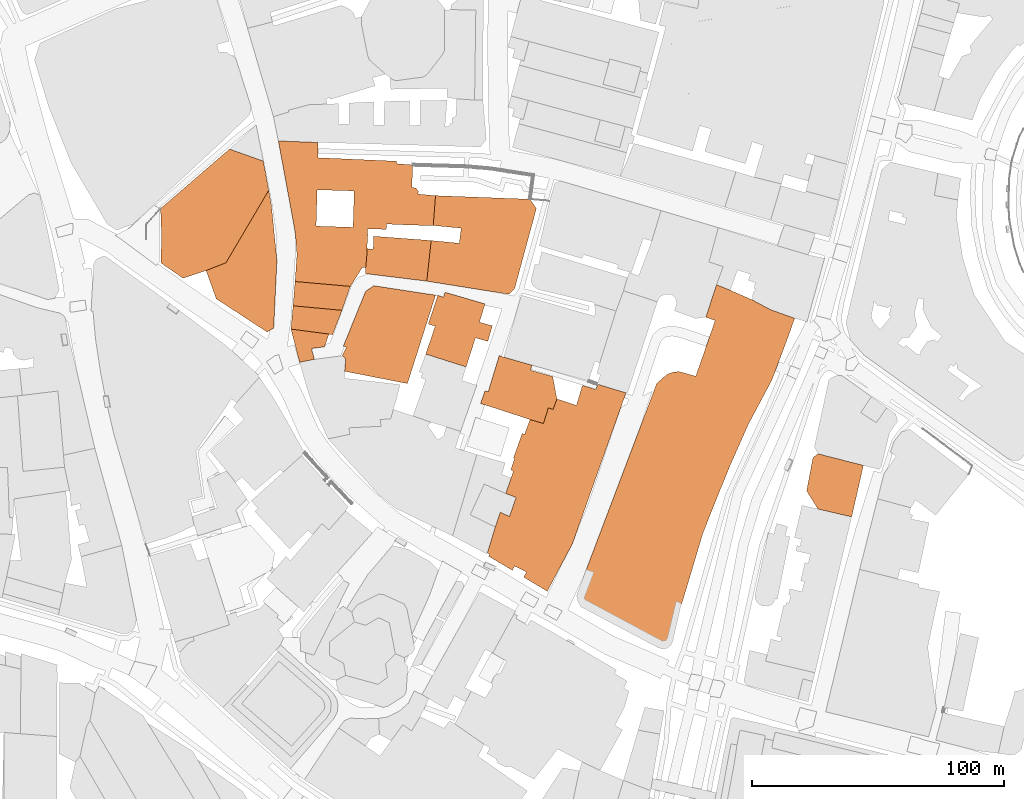
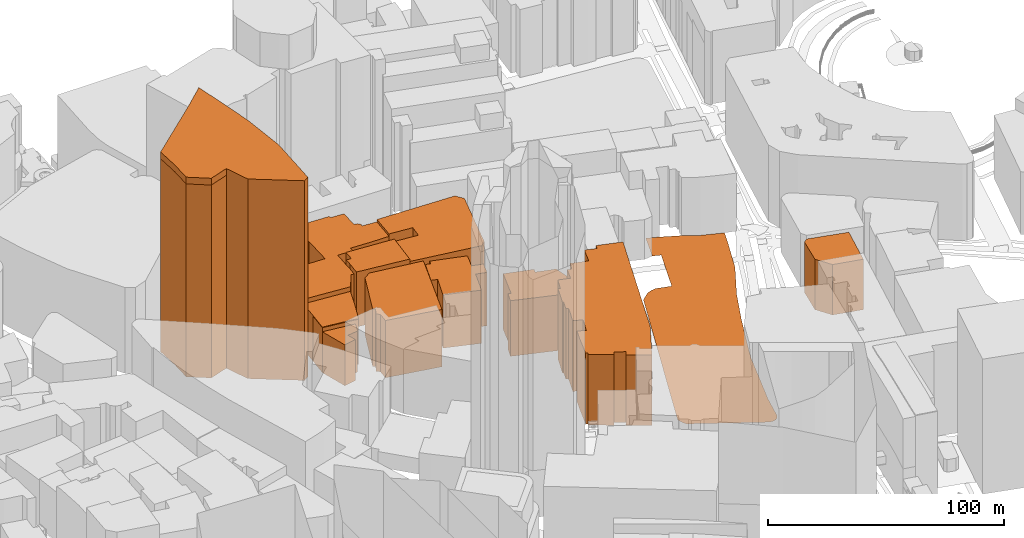
# One storey, part 193 of 200: 14 proxies.
"""IFC4 building model written with IfcOpenShell, lengths in metres."""

from ifc_helpers import new_model, si_unit, origin_with_axes, place, context, subcontext, project, spatial, triangles, material, element, save


model = new_model("IFC4")

# Units and contexts
model_context = context("Model", 3, precision=1e-05, world=origin_with_axes())
body_context = subcontext(model_context, "Body", "Model", "MODEL_VIEW")
ifc_project = project(units=[si_unit("VOLUMEUNIT", "CUBIC_METRE"), si_unit("LENGTHUNIT", "METRE"), si_unit("AREAUNIT", "SQUARE_METRE")], contexts=[model_context])

# Site, building, storey
site_placement = place(None, origin_with_axes())
site = spatial("IfcSite", under=ifc_project, at=site_placement)
building_placement = place(site_placement, origin_with_axes())
building = spatial("IfcBuilding", under=site, at=building_placement, Name="Building")
storey_placement = place(building_placement, origin_with_axes())
storey = spatial("IfcBuildingStorey", under=building, at=storey_placement, Name="Ground")

# Proxies
ifc_material_1 = material()
proxy_1_placement = place(storey_placement, origin_with_axes())
element("IfcBuildingElementProxy", 1, at=proxy_1_placement, inside=storey, material=ifc_material_1, Name="cw_buildings_UK 49", context=body_context, shape_type="Tessellation", body=[
    triangles([(573.4480823661622, -129.90144368040757, 26.014001846313477), (573.0067262512358, -144.32679761538287, 26.014001846313477), (598.6982542588236, -131.13260069638554, 26.014001846313477), (559.1853315662346, -116.73047578070275, 26.014001846313477), (578.7675752678352, -144.90753259443306, 26.014001846313477), (543.3894559962635, -110.06368076658927, 26.014001846313477), (576.7001735573266, -160.19236024323155, 26.014001846313477), (558.7904334898932, -129.4368632945572, 26.014001846313477), (550.7531215891524, -155.10516703122107, 26.014001846313477), (578.0010081344449, -160.30851483643139, 26.014001846313477), (586.2938439957718, -143.0027340189721, 26.014001846313477), (596.3521019426204, -128.50769302611923, 26.014001846313477), (549.5684321084968, -143.58346899802228, 26.014001846313477), (550.1491623391784, -147.2304535171594, 26.014001846313477), (550.0097882234232, -165.81383989244446, 26.014001846313477), (578.4888222879564, -152.80546563105003, 26.014001846313477), (581.3227911318553, -144.9307616137256, 26.014001846313477), (604.8075409389951, -143.6066980173148, 26.014001846313477), (598.9770048645181, -130.0175982736074, 26.014001846313477), (590.289273301034, -119.0998547420141, 26.014001846313477), (559.115644508357, -114.03588105255888, 26.014001846313477), (547.4313433401106, -131.99207441020872, 26.014001846313477), (558.5349142776755, -137.66001209800663, 26.014001846313477), (571.9381818670428, -167.74186748719796, 26.014001846313477), (578.4191352300788, -156.22016945399918, 26.014001846313477), (578.8372623257128, -147.57888880654716, 26.014001846313477), (586.1312408607242, -145.1862808259433, 26.014001846313477), (595.748140318462, -143.44408538552992, 26.014001846313477), (605.6902519817559, -131.7597842172835, 26.014001846313477), (597.7923130096781, -128.71675419975188, 26.014001846313477), (596.6308525483149, -119.58767364389423, 26.014001846313477), (590.1731258303871, -118.10099741569857, 26.014001846313477), (559.115644508357, -110.69087378422451, 26.014001846313477), (544.0166442655301, -113.52484262812348, 26.014001846313477), (558.3490821233353, -143.83898821024, 26.014001846313477), (576.7001735573266, -160.19236024323155, 0.0), (578.0010081344449, -160.30851483643139, 0.0), (571.9381818670428, -167.74186748719796, 0.0), (550.0097882234232, -165.81383989244446, 0.0), (550.7531215891524, -155.10516703122107, 0.0), (550.1491623391784, -147.2304535171594, 0.0), (549.5684321084968, -143.58346899802228, 0.0), (547.4313433401106, -131.99207441020872, 0.0), (544.0166442655301, -113.52484262812348, 0.0), (543.3894559962635, -110.06368076658927, 0.0), (559.115644508357, -110.69087378422451, 0.0), (559.115644508357, -114.03588105255888, 0.0), (559.1853315662346, -116.73047578070275, 0.0), (590.1731258303871, -118.10099741569857, 0.0), (590.289273301034, -119.0998547420141, 0.0), (596.6308525483149, -119.58767364389423, 0.0), (596.3521019426204, -128.50769302611923, 0.0), (597.7923130096781, -128.71675419975188, 0.0), (598.9770048645181, -130.0175982736074, 0.0), (598.6982542588236, -131.13260069638554, 0.0), (605.6902519817559, -131.7597842172835, 0.0), (604.8075409389951, -143.6066980173148, 0.0), (595.748140318462, -143.44408538552992, 0.0), (586.2938439957718, -143.0027340189721, 0.0), (586.1312408607242, -145.1862808259433, 0.0), (581.3227911318553, -144.9307616137256, 0.0), (578.7675752678352, -144.90753259443306, 0.0), (578.8372623257128, -147.57888880654716, 0.0), (578.4888222879564, -152.80546563105003, 0.0), (578.4191352300788, -156.22016945399918, 0.0), (558.5349142776755, -137.66001209800663, 0.0), (558.7904334898932, -129.4368632945572, 0.0), (558.3490821233353, -143.83898821024, 0.0), (573.0067262512358, -144.32679761538287, 0.0), (573.4480823661622, -129.90144368040757, 0.0)], [[1, 2, 3], [3, 4, 1], [2, 5, 3], [4, 6, 1], [2, 7, 5], [6, 8, 1], [2, 9, 7], [7, 10, 5], [5, 11, 3], [3, 12, 4], [6, 13, 8], [2, 14, 9], [9, 15, 7], [10, 16, 5], [5, 17, 11], [11, 18, 3], [3, 19, 12], [12, 20, 4], [4, 21, 6], [6, 22, 13], [13, 23, 8], [2, 13, 14], [15, 24, 7], [10, 25, 16], [16, 26, 5], [17, 27, 11], [11, 28, 18], [18, 29, 3], [19, 30, 12], [12, 31, 20], [20, 32, 4], [21, 33, 6], [6, 34, 22], [13, 35, 23], [2, 35, 13], [36, 37, 10], [36, 10, 7], [38, 36, 7], [38, 7, 24], [39, 38, 24], [39, 24, 15], [40, 39, 15], [40, 15, 9], [41, 40, 9], [41, 9, 14], [42, 41, 14], [42, 14, 13], [43, 42, 13], [43, 13, 22], [44, 43, 22], [44, 22, 34], [45, 44, 34], [45, 34, 6], [46, 45, 6], [46, 6, 33], [47, 46, 33], [47, 33, 21], [48, 47, 21], [48, 21, 4], [49, 48, 4], [49, 4, 32], [50, 49, 32], [50, 32, 20], [51, 50, 20], [51, 20, 31], [52, 51, 31], [52, 31, 12], [53, 52, 12], [53, 12, 30], [54, 53, 30], [54, 30, 19], [55, 54, 19], [55, 19, 3], [56, 55, 3], [56, 3, 29], [57, 56, 29], [57, 29, 18], [58, 57, 18], [58, 18, 28], [59, 58, 28], [59, 28, 11], [60, 59, 11], [60, 11, 27], [61, 60, 27], [61, 27, 17], [62, 61, 17], [62, 17, 5], [63, 62, 5], [63, 5, 26], [64, 63, 26], [64, 26, 16], [65, 64, 16], [65, 16, 25], [37, 65, 25], [37, 25, 10], [66, 67, 8], [66, 8, 23], [68, 66, 23], [68, 23, 35], [69, 68, 35], [69, 35, 2], [70, 69, 2], [70, 2, 1], [67, 70, 1], [67, 1, 8], [42, 68, 69], [66, 68, 42], [43, 44, 45], [45, 46, 47], [48, 49, 50], [50, 51, 52], [52, 53, 54], [55, 56, 57], [57, 58, 59], [59, 60, 61], [62, 63, 64], [64, 65, 37], [36, 38, 39], [41, 42, 69], [67, 66, 42], [42, 43, 45], [45, 47, 48], [48, 50, 52], [52, 54, 55], [55, 57, 59], [59, 61, 62], [62, 64, 37], [36, 39, 40], [40, 41, 69], [67, 42, 45], [48, 52, 55], [55, 59, 62], [62, 37, 36], [36, 40, 69], [70, 67, 45], [62, 36, 69], [70, 45, 48], [55, 62, 69], [70, 48, 55], [55, 69, 70]], closed=False),
])
proxy_2_placement = place(storey_placement, origin_with_axes())
element("IfcBuildingElementProxy", 2, at=proxy_2_placement, inside=storey, material=ifc_material_1, Name="cw_buildings_UK 55", context=body_context, shape_type="Tessellation", body=[
    triangles([(605.5973347174936, -183.53774305716908, 27.597003936767578), (621.5325870741772, -188.13713636077395, 27.597003936767578), (623.1354040214331, -181.95815075180334, 27.597003936767578), (608.84942709575, -172.03927404326282, 27.597003936767578), (601.7877423149403, -194.59486070451752, 27.597003936767578), (626.4107253447888, -189.55410653761757, 27.597003936767578), (625.2957223284646, -174.6874012360844, 27.597003936767578), (602.7865984541636, -182.65503082731615, 27.597003936767578), (617.8159101552478, -199.682053916528, 27.597003936767578), (628.2458344881879, -183.35191090282893, 27.597003936767578), (609.4301585135238, -170.0647884099243, 27.597003936767578), (606.6194210631016, -171.295935929165, 27.597003936767578), (609.4301585135238, -170.0647884099243, 0.0), (608.84942709575, -172.03927404326282, 0.0), (625.2957223284646, -174.6874012360844, 0.0), (623.1354040214331, -181.95815075180334, 0.0), (628.2458344881879, -183.35191090282893, 0.0), (626.4107253447888, -189.55410653761757, 0.0), (621.5325870741772, -188.13713636077395, 0.0), (617.8159101552478, -199.682053916528, 0.0), (601.7877423149403, -194.59486070451752, 0.0), (605.5973347174936, -183.53774305716908, 0.0), (602.7865984541636, -182.65503082731615, 0.0), (606.6194210631016, -171.295935929165, 0.0)], [[1, 2, 3], [3, 4, 1], [1, 5, 2], [2, 6, 3], [3, 7, 4], [4, 8, 1], [5, 9, 2], [6, 10, 3], [7, 11, 4], [4, 12, 8], [13, 14, 4], [13, 4, 11], [15, 13, 11], [15, 11, 7], [16, 15, 7], [16, 7, 3], [17, 16, 3], [17, 3, 10], [18, 17, 10], [18, 10, 6], [19, 18, 6], [19, 6, 2], [20, 19, 2], [20, 2, 9], [21, 20, 9], [21, 9, 5], [22, 21, 5], [22, 5, 1], [23, 22, 1], [23, 1, 8], [24, 23, 8], [24, 8, 12], [14, 24, 12], [14, 12, 4], [23, 24, 14], [14, 13, 15], [16, 17, 18], [19, 20, 21], [22, 23, 14], [14, 15, 16], [16, 18, 19], [19, 21, 22], [22, 14, 16], [16, 19, 22]], closed=False),
])
proxy_3_placement = place(storey_placement, origin_with_axes())
element("IfcBuildingElementProxy", 3, at=proxy_3_placement, inside=storey, material=ifc_material_1, Name="cw_buildings_UK 59", context=body_context, shape_type="Tessellation", body=[
    triangles([(637.6304431594544, -251.43678373712103, 36.62324142456055), (635.0055402375568, -258.96304296832045, 36.62324142456055), (650.0116232161215, -288.6500145262762, 36.62324142456055), (640.9986818212657, -226.39567301809242, 36.62324142456055), (641.7420175611792, -281.0075912051397, 36.62324142456055), (661.5797792879054, -214.89719450744892, 36.62324142456055), (640.0462837206273, -226.07046674799716, 36.62324142456055), (637.0961709673579, -278.6149832245358, 36.62324142456055), (669.3383429571358, -208.67176035663056, 36.62324142456055), (648.4784936977095, -222.09826646202757, 36.62324142456055), (636.5386697559688, -240.96040106882285, 36.62324142456055), (627.1772901039949, -273.94591235979067, 36.62324142456055), (669.9190731878174, -206.51144256895185, 36.62324142456055), (652.3345465130321, -216.52324485139968, 36.62324142456055), (637.0729419480654, -235.9196469019229, 36.62324142456055), (635.7024179388852, -243.67821531952197, 36.62324142456055), (629.3608375045121, -263.1210754086302, 36.62324142456055), (626.712705563322, -274.71246999644376, 36.62324142456055), (681.2317100473834, -209.97260443048606, 36.62324142456055), (669.6170959370146, -207.55676743058967, 36.62324142456055), (663.9723920168778, -206.92958390969167, 36.62324142456055), (653.8212179928591, -212.38844143038244, 36.62324142456055), (650.4297503117555, -215.8960613305017, 36.62324142456055), (643.1590007960365, -220.54190317595433, 36.62324142456055), (636.585127794554, -235.78027278616779, 36.62324142456055), (635.5165834103608, -240.519049702265, 36.62324142456055), (633.5188699448219, -249.8571914317553, 36.62324142456055), (631.3353225443046, -257.29055357925915, 36.62324142456055), (626.2713500419416, -273.38839690329576, 36.62324142456055), (636.1670018860121, -280.3339496456567, 36.62324142456055), (640.6037849320164, -283.0053058577708, 36.62324142456055), (660.0234207502008, -269.74142188089587, 36.62324142456055), (640.6037849320164, -283.0053058577708, 0.0), (650.0116232161215, -288.6500145262762, 0.0), (641.7420175611792, -281.0075912051397, 0.0), (637.0961709673579, -278.6149832245358, 0.0), (636.1670018860121, -280.3339496456567, 0.0), (626.712705563322, -274.71246999644376, 0.0), (627.1772901039949, -273.94591235979067, 0.0), (626.2713500419416, -273.38839690329576, 0.0), (629.3608375045121, -263.1210754086302, 0.0), (631.3353225443046, -257.29055357925915, 0.0), (635.0055402375568, -258.96304296832045, 0.0), (637.6304431594544, -251.43678373712103, 0.0), (633.5188699448219, -249.8571914317553, 0.0), (635.7024179388852, -243.67821531952197, 0.0), (636.5386697559688, -240.96040106882285, 0.0), (635.5165834103608, -240.519049702265, 0.0), (637.0729419480654, -235.9196469019229, 0.0), (636.585127794554, -235.78027278616779, 0.0), (640.0462837206273, -226.07046674799716, 0.0), (640.9986818212657, -226.39567301809242, 0.0), (643.1590007960365, -220.54190317595433, 0.0), (648.4784936977095, -222.09826646202757, 0.0), (650.4297503117555, -215.8960613305017, 0.0), (652.3345465130321, -216.52324485139968, 0.0), (653.8212179928591, -212.38844143038244, 0.0), (661.5797792879054, -214.89719450744892, 0.0), (663.9723920168778, -206.92958390969167, 0.0), (669.3383429571358, -208.67176035663056, 0.0), (669.6170959370146, -207.55676743058967, 0.0), (669.9190731878174, -206.51144256895185, 0.0), (681.2317100473834, -209.97260443048606, 0.0), (660.0234207502008, -269.74142188089587, 0.0)], [[1, 2, 3], [3, 4, 1], [2, 5, 3], [3, 6, 4], [4, 7, 1], [2, 8, 5], [3, 9, 6], [6, 10, 4], [7, 11, 1], [2, 12, 8], [3, 13, 9], [6, 14, 10], [7, 15, 11], [11, 16, 1], [2, 17, 12], [12, 18, 8], [3, 19, 13], [13, 20, 9], [9, 21, 6], [6, 22, 14], [14, 23, 10], [10, 24, 4], [7, 25, 15], [15, 26, 11], [16, 27, 1], [2, 28, 17], [17, 29, 12], [18, 30, 8], [5, 31, 3], [3, 32, 19], [33, 34, 3], [33, 3, 31], [35, 33, 31], [35, 31, 5], [36, 35, 5], [36, 5, 8], [37, 36, 8], [37, 8, 30], [38, 37, 30], [38, 30, 18], [39, 38, 18], [39, 18, 12], [40, 39, 12], [40, 12, 29], [41, 40, 29], [41, 29, 17], [42, 41, 17], [42, 17, 28], [43, 42, 28], [43, 28, 2], [44, 43, 2], [44, 2, 1], [45, 44, 1], [45, 1, 27], [46, 45, 27], [46, 27, 16], [47, 46, 16], [47, 16, 11], [48, 47, 11], [48, 11, 26], [49, 48, 26], [49, 26, 15], [50, 49, 15], [50, 15, 25], [51, 50, 25], [51, 25, 7], [52, 51, 7], [52, 7, 4], [53, 52, 4], [53, 4, 24], [54, 53, 24], [54, 24, 10], [55, 54, 10], [55, 10, 23], [56, 55, 23], [56, 23, 14], [57, 56, 14], [57, 14, 22], [58, 57, 22], [58, 22, 6], [59, 58, 6], [59, 6, 21], [60, 59, 21], [60, 21, 9], [61, 60, 9], [61, 9, 20], [62, 61, 20], [62, 20, 13], [63, 62, 13], [63, 13, 19], [64, 63, 19], [64, 19, 32], [34, 64, 32], [34, 32, 3], [63, 64, 34], [34, 33, 35], [36, 37, 38], [39, 40, 41], [41, 42, 43], [44, 45, 46], [47, 48, 49], [49, 50, 51], [52, 53, 54], [54, 55, 56], [56, 57, 58], [58, 59, 60], [60, 61, 62], [62, 63, 34], [36, 38, 39], [39, 41, 43], [44, 46, 47], [47, 49, 51], [54, 56, 58], [60, 62, 34], [36, 39, 43], [44, 47, 51], [52, 54, 58], [58, 60, 34], [35, 36, 43], [44, 51, 52], [52, 58, 34], [34, 35, 43], [44, 52, 34], [34, 43, 44]], closed=False),
])
proxy_4_placement = place(storey_placement, origin_with_axes())
element("IfcBuildingElementProxy", 4, at=proxy_4_placement, inside=storey, material=ifc_material_1, Name="cw_buildings_UK 61", context=body_context, shape_type="Tessellation", body=[
    triangles([(626.5733299637017, -209.57771110251323, 28.83700180053711), (650.4297503117555, -215.8960613305017, 28.83700180053711), (643.344835324561, -200.98289799038352, 28.83700180053711), (643.7165020074256, -199.77496999369808, 28.83700180053711), (643.1590007960365, -220.54190317595433, 28.83700180053711), (653.8212179928591, -212.38844143038244, 28.83700180053711), (632.7290761663234, -195.77954068843593, 28.83700180053711), (625.3421809605958, -209.13635973595538, 28.83700180053711), (648.4784936977095, -222.09826646202757, 28.83700180053711), (652.3345465130321, -216.52324485139968, 28.83700180053711), (652.1719410038002, -203.49165106744996, 28.83700180053711), (643.9487945745351, -198.96195431845993, 28.83700180053711), (630.9404256550554, -195.2220442254155, 28.83700180053711), (623.5535301525547, -214.15386589008833, 28.83700180053711), (626.5733299637017, -209.57771110251323, 0.0), (625.3421809605958, -209.13635973595538, 0.0), (630.9404256550554, -195.2220442254155, 0.0), (632.7290761663234, -195.77954068843593, 0.0), (643.9487945745351, -198.96195431845993, 0.0), (643.7165020074256, -199.77496999369808, 0.0), (643.344835324561, -200.98289799038352, 0.0), (652.1719410038002, -203.49165106744996, 0.0), (653.8212179928591, -212.38844143038244, 0.0), (652.3345465130321, -216.52324485139968, 0.0), (650.4297503117555, -215.8960613305017, 0.0), (648.4784936977095, -222.09826646202757, 0.0), (643.1590007960365, -220.54190317595433, 0.0), (623.5535301525547, -214.15386589008833, 0.0)], [[1, 2, 3], [3, 4, 1], [1, 5, 2], [2, 6, 3], [4, 7, 1], [1, 8, 5], [5, 9, 2], [2, 10, 6], [6, 11, 3], [4, 12, 7], [7, 13, 1], [8, 14, 5], [15, 16, 8], [15, 8, 1], [17, 15, 1], [17, 1, 13], [18, 17, 13], [18, 13, 7], [19, 18, 7], [19, 7, 12], [20, 19, 12], [20, 12, 4], [21, 20, 4], [21, 4, 3], [22, 21, 3], [22, 3, 11], [23, 22, 11], [23, 11, 6], [24, 23, 6], [24, 6, 10], [25, 24, 10], [25, 10, 2], [26, 25, 2], [26, 2, 9], [27, 26, 9], [27, 9, 5], [28, 27, 5], [28, 5, 14], [16, 28, 14], [16, 14, 8], [27, 28, 16], [15, 17, 18], [18, 19, 20], [21, 22, 23], [23, 24, 25], [25, 26, 27], [27, 16, 15], [15, 18, 20], [21, 23, 25], [25, 27, 15], [15, 20, 21], [21, 25, 15]], closed=False),
])
proxy_5_placement = place(storey_placement, origin_with_axes())
element("IfcBuildingElementProxy", 5, at=proxy_5_placement, inside=storey, material=ifc_material_1, Name="cw_buildings_UK 62", context=body_context, shape_type="Tessellation", body=[
    triangles([(570.0798413301668, -196.476430260686, 29.709003448486328), (603.4602459491074, -178.33439525195877, 29.709003448486328), (577.9545500958598, -169.73958213982903, 29.709003448486328), (570.2889025037995, -191.9002564796364, 29.709003448486328), (569.6617142345328, -201.40102033764884, 29.709003448486328), (605.7134810010483, -171.22624887128745, 29.709003448486328), (569.1506710617288, -191.43567609378604, 29.709003448486328), (568.7093149468024, -195.2220442254155, 29.709003448486328), (594.5634508378063, -206.27915237602667, 29.709003448486328), (604.296497766191, -175.732716600985, 29.709003448486328), (581.2066412870241, -167.486338778243, 29.709003448486328), (604.296497766191, -175.732716600985, 0.0), (605.7134810010483, -171.22624887128745, 0.0), (603.4602459491074, -178.33439525195877, 0.0), (594.5634508378063, -206.27915237602667, 0.0), (569.6617142345328, -201.40102033764884, 0.0), (570.0798413301668, -196.476430260686, 0.0), (568.7093149468024, -195.2220442254155, 0.0), (570.2889025037995, -191.9002564796364, 0.0), (569.1506710617288, -191.43567609378604, 0.0), (577.9545500958598, -169.73958213982903, 0.0), (581.2066412870241, -167.486338778243, 0.0)], [[1, 2, 3], [3, 4, 1], [1, 5, 2], [2, 6, 3], [3, 7, 4], [4, 8, 1], [5, 9, 2], [2, 10, 6], [6, 11, 3], [12, 13, 6], [12, 6, 10], [14, 12, 10], [14, 10, 2], [15, 14, 2], [15, 2, 9], [16, 15, 9], [16, 9, 5], [17, 16, 5], [17, 5, 1], [18, 17, 1], [18, 1, 8], [19, 18, 8], [19, 8, 4], [20, 19, 4], [20, 4, 7], [21, 20, 7], [21, 7, 3], [22, 21, 3], [22, 3, 11], [13, 22, 11], [13, 11, 6], [21, 22, 13], [13, 12, 14], [14, 15, 16], [17, 18, 19], [19, 20, 21], [21, 13, 14], [14, 16, 17], [17, 19, 21], [21, 14, 17]], closed=False),
])
proxy_6_placement = place(storey_placement, origin_with_axes())
element("IfcBuildingElementProxy", 6, at=proxy_6_placement, inside=storey, material=ifc_material_1, Name="cw_buildings_UK 81", context=body_context, shape_type="Tessellation", body=[
    triangles([(755.3794138974463, -235.5479825932426, 26.13800048828125), (757.3074414921998, -256.01293852469615, 26.13800048828125), (773.0336300042934, -248.85834360217703, 26.13800048828125), (775.3565509270197, -238.73039622326658, 26.13800048828125), (752.8474223043501, -248.8351145828845, 26.13800048828125), (770.6874800622745, -259.14889411613507, 26.13800048828125), (757.3538995307849, -234.10778339710646, 26.13800048828125), (773.0336300042934, -248.85834360217703, 0.0), (775.3565509270197, -238.73039622326658, 0.0), (770.6874800622745, -259.14889411613507, 0.0), (757.3074414921998, -256.01293852469615, 0.0), (752.8474223043501, -248.8351145828845, 0.0), (755.3794138974463, -235.5479825932426, 0.0), (757.3538995307849, -234.10778339710646, 0.0)], [[1, 2, 3], [3, 4, 1], [1, 5, 2], [2, 6, 3], [4, 7, 1], [8, 9, 4], [8, 4, 3], [10, 8, 3], [10, 3, 6], [11, 10, 6], [11, 6, 2], [12, 11, 2], [12, 2, 5], [13, 12, 5], [13, 5, 1], [14, 13, 1], [14, 1, 7], [9, 14, 7], [9, 7, 4], [13, 14, 9], [8, 10, 11], [11, 12, 13], [13, 9, 8], [8, 11, 13]], closed=False),
])
proxy_7_placement = place(storey_placement, origin_with_axes())
element("IfcBuildingElementProxy", 7, at=proxy_7_placement, inside=storey, material=ifc_material_1, Name="cw_buildings_UK 89", context=body_context, shape_type="Tessellation", body=[
    triangles([(645.6909876407641, -136.87021594532376, 27.26300048828125), (615.864655025067, -144.65201338221536, 27.26300048828125), (615.1213192851535, -150.64514784337132, 27.26300048828125), (634.7267896318623, -170.85458456260716, 27.26300048828125), (605.6902519817559, -131.7597842172835, 27.26300048828125), (603.9712891219115, -149.55337443988572, 27.26300048828125), (604.8075409389951, -143.6066980173148, 27.26300048828125), (602.2290960556824, -165.67446577668935, 27.26300048828125), (637.0497129287729, -168.69426677492845, 27.26300048828125), (643.135771776744, -133.17677338760163, 27.26300048828125), (637.0497129287729, -168.69426677492845, 0.0), (645.6909876407641, -136.87021594532376, 0.0), (634.7267896318623, -170.85458456260716, 0.0), (602.2290960556824, -165.67446577668935, 0.0), (603.9712891219115, -149.55337443988572, 0.0), (615.1213192851535, -150.64514784337132, 0.0), (615.864655025067, -144.65201338221536, 0.0), (604.8075409389951, -143.6066980173148, 0.0), (605.6902519817559, -131.7597842172835, 0.0), (643.135771776744, -133.17677338760163, 0.0)], [[1, 2, 3], [3, 4, 1], [1, 5, 2], [3, 6, 4], [5, 7, 2], [6, 8, 4], [4, 9, 1], [1, 10, 5], [11, 12, 1], [11, 1, 9], [13, 11, 9], [13, 9, 4], [14, 13, 4], [14, 4, 8], [15, 14, 8], [15, 8, 6], [16, 15, 6], [16, 6, 3], [17, 16, 3], [17, 3, 2], [18, 17, 2], [18, 2, 7], [19, 18, 7], [19, 7, 5], [20, 19, 5], [20, 5, 10], [12, 20, 10], [12, 10, 1], [19, 20, 12], [12, 11, 13], [13, 14, 15], [17, 18, 19], [13, 15, 16], [17, 19, 12], [12, 13, 16], [16, 17, 12]], closed=False),
])
proxy_8_placement = place(storey_placement, origin_with_axes())
element("IfcBuildingElementProxy", 8, at=proxy_8_placement, inside=storey, material=ifc_material_1, Name="cw_buildings_UK 90", context=body_context, shape_type="Tessellation", body=[
    triangles([(602.2290960556824, -165.67446577668935, 28.520004272460938), (580.9743510940989, -152.89838170822009, 28.520004272460938), (578.4191352300788, -156.22016945399918, 28.520004272460938), (578.0010081344449, -160.30851483643139, 28.520004272460938), (581.1834122677316, -147.85764653479464, 28.520004272460938), (578.4888222879564, -152.80546563105003, 28.520004272460938), (577.8384049993972, -162.67789379774274, 28.520004272460938), (603.9712891219115, -149.55337443988572, 28.520004272460938), (577.8384049993972, -162.67789379774274, 0.0), (602.2290960556824, -165.67446577668935, 0.0), (578.0010081344449, -160.30851483643139, 0.0), (578.4191352300788, -156.22016945399918, 0.0), (578.4888222879564, -152.80546563105003, 0.0), (580.9743510940989, -152.89838170822009, 0.0), (581.1834122677316, -147.85764653479464, 0.0), (603.9712891219115, -149.55337443988572, 0.0)], [[1, 2, 3], [3, 4, 1], [1, 5, 2], [2, 6, 3], [4, 7, 1], [1, 8, 5], [9, 10, 1], [9, 1, 7], [11, 9, 7], [11, 7, 4], [12, 11, 4], [12, 4, 3], [13, 12, 3], [13, 3, 6], [14, 13, 6], [14, 6, 2], [15, 14, 2], [15, 2, 5], [16, 15, 5], [16, 5, 8], [10, 16, 8], [10, 8, 1], [15, 16, 10], [10, 9, 11], [12, 13, 14], [14, 15, 10], [10, 11, 12], [12, 14, 10]], closed=False),
])
ifc_material_2 = material(Name="OSM buildings")
proxy_9_placement = place(storey_placement, origin_with_axes())
element("IfcBuildingElementProxy", 9, at=proxy_9_placement, inside=storey, material=ifc_material_2, Name="cw_buildings_ buildings_14", context=body_context, shape_type="Tessellation", body=[
    triangles([(522.6051088363523, -158.38048724167788, 100.0), (523.9988499939034, -113.2925524351983, 100.0), (497.0993987379988, -148.18285280488988, 100.0), (505.60131476643295, -164.51300531532618, 100.0), (539.0049294111916, -126.53320739278068, 100.0), (496.68127639073344, -136.87021594532376, 100.0), (496.77419246790356, -158.4269452802629, 100.0), (514.7303953222906, -161.44674627850202, 100.0), (539.5624448676865, -129.64592446818986, 100.0), (537.4485851185929, -118.07776839640606, 100.0), (519.8175885343011, -116.89307891575037, 100.0), (537.4485851185929, -118.07776839640606, 0.0), (523.9988499939034, -113.2925524351983, 0.0), (539.0049294111916, -126.53320739278068, 0.0), (539.5624448676865, -129.64592446818986, 0.0), (522.6051088363523, -158.38048724167788, 0.0), (514.7303953222906, -161.44674627850202, 0.0), (505.60131476643295, -164.51300531532618, 0.0), (496.77419246790356, -158.4269452802629, 0.0), (497.0993987379988, -148.18285280488988, 0.0), (496.68127639073344, -136.87021594532376, 0.0), (519.8175885343011, -116.89307891575037, 0.0)], [[1, 2, 3], [3, 4, 1], [1, 5, 2], [2, 6, 3], [3, 7, 4], [4, 8, 1], [1, 9, 5], [5, 10, 2], [2, 11, 6], [12, 13, 2], [12, 2, 10], [14, 12, 10], [14, 10, 5], [15, 14, 5], [15, 5, 9], [16, 15, 9], [16, 9, 1], [17, 16, 1], [17, 1, 8], [18, 17, 8], [18, 8, 4], [19, 18, 4], [19, 4, 7], [20, 19, 7], [20, 7, 3], [21, 20, 3], [21, 3, 6], [22, 21, 6], [22, 6, 11], [13, 22, 11], [13, 11, 2], [21, 22, 13], [13, 12, 14], [14, 15, 16], [16, 17, 18], [18, 19, 20], [20, 21, 13], [13, 14, 16], [16, 18, 20], [20, 13, 16]], closed=False),
])
proxy_10_placement = place(storey_placement, origin_with_axes())
element("IfcBuildingElementProxy", 10, at=proxy_10_placement, inside=storey, material=ifc_material_1, Name="cw_buildings_UK 183", context=body_context, shape_type="Tessellation", body=[
    triangles([(549.2257928672722, -175.43073935018225, 23.632999420166016), (563.4421046220892, -186.65046013257827, 23.632999420166016), (564.8590558054584, -186.97566640267354, 23.632999420166016), (571.944001657049, -167.74186748719796, 23.632999420166016), (548.3895481727415, -184.67597449923974, 23.632999420166016), (568.5989848919774, -177.24262184847316, 23.632999420166016), (550.0155985166923, -165.81383989244446, 23.632999420166016), (571.944001657049, -167.74186748719796, 0.0), (550.0155985166923, -165.81383989244446, 0.0), (568.5989848919774, -177.24262184847316, 0.0), (564.8590558054584, -186.97566640267354, 0.0), (563.4421046220892, -186.65046013257827, 0.0), (548.3895481727415, -184.67597449923974, 0.0), (549.2257928672722, -175.43073935018225, 0.0)], [[1, 2, 3], [3, 4, 1], [1, 5, 2], [3, 6, 4], [4, 7, 1], [8, 9, 7], [8, 7, 4], [10, 8, 4], [10, 4, 6], [11, 10, 6], [11, 6, 3], [12, 11, 3], [12, 3, 2], [13, 12, 2], [13, 2, 5], [14, 13, 5], [14, 5, 1], [9, 14, 1], [9, 1, 7], [14, 9, 8], [8, 10, 11], [12, 13, 14], [14, 8, 11], [11, 12, 14]], closed=False),
])
proxy_11_placement = place(storey_placement, origin_with_axes())
element("IfcBuildingElementProxy", 11, at=proxy_11_placement, inside=storey, material=ifc_material_1, Name="cw_buildings_UK 184", context=body_context, shape_type="Tessellation", body=[
    triangles([(539.5624448676865, -129.64592446818986, 103.50200653076172), (497.0993987379988, -148.18285280488988, 103.50200653076172), (514.7303953222906, -161.44674627850202, 103.50200653076172), (538.9817003918992, -185.88389299918794, 103.50200653076172), (523.9988499939034, -113.2925524351983, 103.50200653076172), (496.77419246790356, -158.4269452802629, 103.50200653076172), (542.8145265621137, -157.31194285748478, 103.50200653076172), (537.4485851185929, -118.07776839640606, 103.50200653076172), (496.68127639073344, -136.87021594532376, 103.50200653076172), (505.60131476643295, -164.51300531532618, 103.50200653076172), (518.7722826661378, -172.68968658345335, 103.50200653076172), (541.5369305010252, -184.23461363594464, 103.50200653076172), (540.5845217165573, -135.19770756278797, 103.50200653076172), (539.0049294111916, -126.53320739278068, 103.50200653076172), (534.5681487393716, -103.6988772483844, 103.50200653076172), (519.8175885343011, -116.89307891575037, 103.50200653076172), (537.4485851185929, -118.07776839640606, 0.0), (534.5681487393716, -103.6988772483844, 0.0), (539.0049294111916, -126.53320739278068, 0.0), (539.5624448676865, -129.64592446818986, 0.0), (540.5845217165573, -135.19770756278797, 0.0), (542.8145265621137, -157.31194285748478, 0.0), (541.5369305010252, -184.23461363594464, 0.0), (538.9817003918992, -185.88389299918794, 0.0), (518.7722826661378, -172.68968658345335, 0.0), (514.7303953222906, -161.44674627850202, 0.0), (505.60131476643295, -164.51300531532618, 0.0), (496.77419246790356, -158.4269452802629, 0.0), (497.0993987379988, -148.18285280488988, 0.0), (496.68127639073344, -136.87021594532376, 0.0), (519.8175885343011, -116.89307891575037, 0.0), (523.9988499939034, -113.2925524351983, 0.0)], [[1, 2, 3], [3, 4, 1], [1, 5, 2], [2, 6, 3], [4, 7, 1], [1, 8, 5], [5, 9, 2], [6, 10, 3], [3, 11, 4], [4, 12, 7], [7, 13, 1], [1, 14, 8], [8, 15, 5], [5, 16, 9], [17, 18, 15], [17, 15, 8], [19, 17, 8], [19, 8, 14], [20, 19, 14], [20, 14, 1], [21, 20, 1], [21, 1, 13], [22, 21, 13], [22, 13, 7], [23, 22, 7], [23, 7, 12], [24, 23, 12], [24, 12, 4], [25, 24, 4], [25, 4, 11], [26, 25, 11], [26, 11, 3], [27, 26, 3], [27, 3, 10], [28, 27, 10], [28, 10, 6], [29, 28, 6], [29, 6, 2], [30, 29, 2], [30, 2, 9], [31, 30, 9], [31, 9, 16], [32, 31, 16], [32, 16, 5], [18, 32, 5], [18, 5, 15], [30, 31, 32], [32, 18, 17], [17, 19, 20], [20, 21, 22], [22, 23, 24], [24, 25, 26], [26, 27, 28], [29, 30, 32], [32, 17, 20], [20, 22, 24], [26, 28, 29], [29, 32, 20], [20, 24, 26], [26, 29, 20]], closed=False),
])
proxy_12_placement = place(storey_placement, origin_with_axes())
element("IfcBuildingElementProxy", 12, at=proxy_12_placement, inside=storey, material=ifc_material_1, Name="cw_buildings_UK 236", context=body_context, shape_type="Tessellation", body=[
    triangles([(550.9679883076855, -194.66454776239505, 21.219003677368164), (551.7810229763982, -197.84694239894455, 21.219003677368164), (556.5430099183134, -192.38808487825378, 21.219003677368164), (563.4421046220892, -186.65046013257827, 21.219003677368164), (557.6347738250618, -196.68549143431864, 21.219003677368164), (561.6999091816759, -191.66796628671122, 21.219003677368164), (548.3895481727415, -184.67597449923974, 21.219003677368164), (563.4421046220892, -186.65046013257827, 0.0), (548.3895481727415, -184.67597449923974, 0.0), (561.6999091816759, -191.66796628671122, 0.0), (556.5430099183134, -192.38808487825378, 0.0), (557.6347738250618, -196.68549143431864, 0.0), (551.7810229763982, -197.84694239894455, 0.0), (550.9679883076855, -194.66454776239505, 0.0)], [[1, 2, 3], [3, 4, 1], [2, 5, 3], [3, 6, 4], [4, 7, 1], [8, 9, 7], [8, 7, 4], [10, 8, 4], [10, 4, 6], [11, 10, 6], [11, 6, 3], [12, 11, 3], [12, 3, 5], [13, 12, 5], [13, 5, 2], [14, 13, 2], [14, 2, 1], [9, 14, 1], [9, 1, 7], [14, 9, 8], [8, 10, 11], [11, 12, 13], [14, 8, 11], [11, 13, 14]], closed=False),
])
proxy_13_placement = place(storey_placement, origin_with_axes())
element("IfcBuildingElementProxy", 13, at=proxy_13_placement, inside=storey, material=ifc_material_1, Name="cw_buildings_UK 237", context=body_context, shape_type="Tessellation", body=[
    triangles([(549.2257928672722, -175.43073935018225, 23.279003143310547), (563.4421046220892, -186.65046013257827, 23.279003143310547), (564.8590558054584, -186.97566640267354, 23.279003143310547), (568.5989848919774, -177.24262184847316, 23.279003143310547), (548.3895481727415, -184.67597449923974, 23.279003143310547), (549.2257928672722, -175.43073935018225, 0.0), (548.3895481727415, -184.67597449923974, 0.0), (568.5989848919774, -177.24262184847316, 0.0), (564.8590558054584, -186.97566640267354, 0.0), (563.4421046220892, -186.65046013257827, 0.0)], [[1, 2, 3], [3, 4, 1], [1, 5, 2], [6, 7, 5], [6, 5, 1], [8, 6, 1], [8, 1, 4], [9, 8, 4], [9, 4, 3], [10, 9, 3], [10, 3, 2], [7, 10, 2], [7, 2, 5], [10, 7, 6], [6, 8, 9], [9, 10, 6]], closed=False),
])
ifc_material_3 = material(Name="buildingConstruction")
proxy_14_placement = place(storey_placement, origin_with_axes())
element("IfcBuildingElementProxy", 14, at=proxy_14_placement, inside=storey, material=ifc_material_3, Name="cw_surface_buildingConstruction_2", ObjectType="Building Construction", context=body_context, shape_type="Tessellation", body=[
    triangles([(661.6030106813822, -290.25281685745995, 0.0), (717.1208677433906, -251.94782216155645, 0.0), (722.510047702941, -238.7536252425591, 0.0), (729.8040262379526, -222.28409861636771, 0.0), (711.6620007259626, -265.72276355634125, 0.0), (708.8977189399411, -203.37550597098738, 0.0), (697.6547738866212, -311.1591241554714, 0.0), (731.2674734468557, -173.0845894081634, 0.0), (697.5850868287437, -202.5857003215673, 0.0), (677.9796188562192, -302.5643110433416, 0.0), (702.5793687119527, -296.0368996417205, 0.0), (745.8554305168786, -186.76660522904086, 0.0), (716.5633712803701, -181.28450919232031, 0.0), (693.4038253691414, -206.23269433744164, 0.0), (663.275511941365, -294.7825325999245, 0.0), (693.984555599823, -311.04297905900876, 0.0), (699.7918626550074, -308.4180808854797, 0.0), (703.3459358453431, -293.55137558394654, 0.0), (739.1189484448876, -204.76926612201297, 0.0), (738.3988488468195, -176.91740608164065, 0.0), (717.1208677433906, -167.06821643097769, 0.0), (699.9544705384236, -201.7494556270366, 0.0), (695.4015400217725, -204.4208118391507, 0.0), (665.4822925159974, -279.9622853369764, 0.0), (662.1140514800019, -292.5060697157832, 0.0), (672.2884568974973, -299.56774856113225, 0.0), (695.889354175284, -311.57726549621117, 0.0), (699.0485292892782, -310.02090221013793, 0.0), (702.1380173453948, -298.08107233293657, 0.0), (707.0393878998025, -281.26311041735744, 0.0), (741.0702050589337, -199.58913783935793, 0.0), (748.0854353624349, -180.4017969624674, 0.0), (722.5797347608186, -169.27499225724142, 0.0), (712.8699192259107, -179.93720707987978, 0.0), (702.1844753839799, -201.4939364148189, 0.0)], [[1, 2, 3], [3, 4, 1], [1, 5, 2], [4, 6, 1], [1, 7, 5], [4, 8, 6], [6, 9, 1], [1, 10, 7], [7, 11, 5], [4, 12, 8], [8, 13, 6], [9, 14, 1], [1, 15, 10], [10, 16, 7], [7, 17, 11], [11, 18, 5], [4, 19, 12], [12, 20, 8], [8, 21, 13], [6, 22, 9], [9, 23, 14], [14, 24, 1], [1, 25, 15], [15, 26, 10], [16, 27, 7], [7, 28, 17], [17, 29, 11], [18, 30, 5], [19, 31, 12], [12, 32, 20], [8, 33, 21], [21, 34, 13], [6, 35, 22]], closed=True),
])

save(model, "model.ifc")
